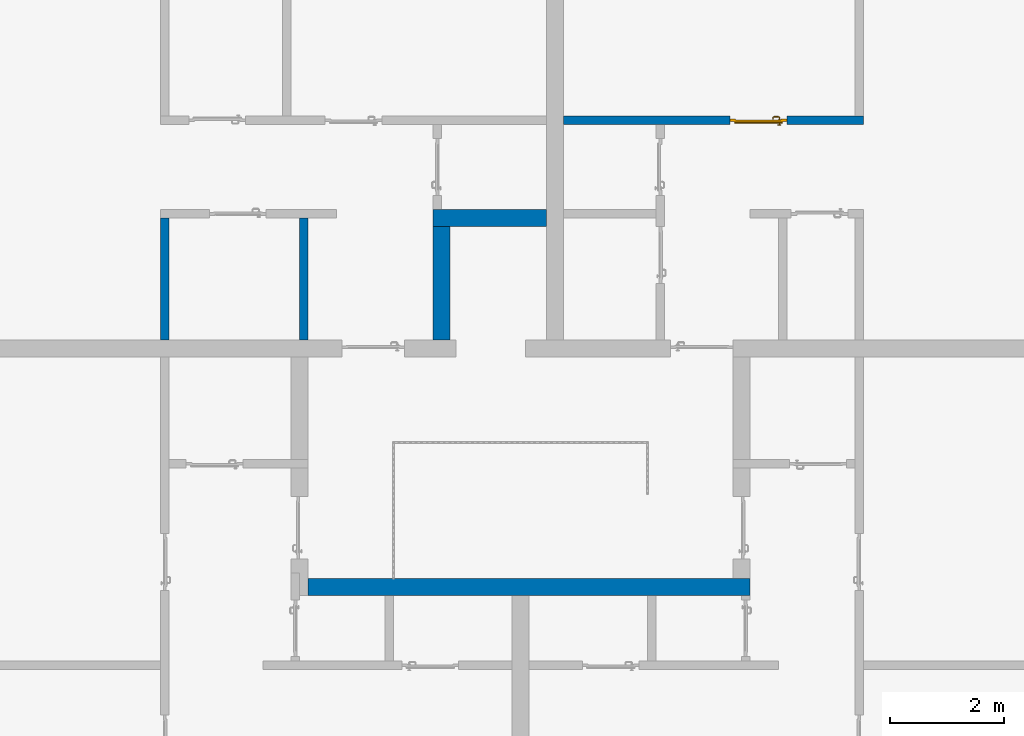
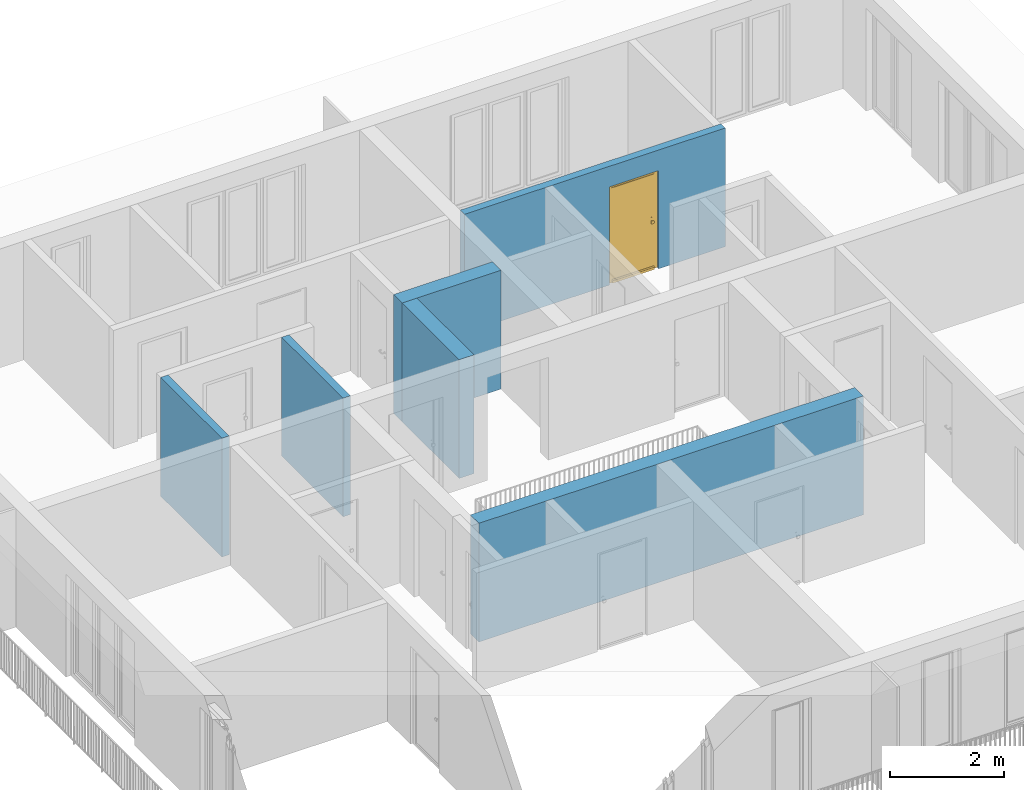
# One storey, part 30 of 54: 6 walls, 1 door, 1 opening.
"""IFC4 building model written with IfcOpenShell, lengths in metres."""

import ifcopenshell
import ifcopenshell.guid

model = None  # the IFC model being written
_history = None  # IfcOwnerHistory: only IFC2X3 demands one
_inside = {}  # id of a spatial element -> (the spatial element, [elements in it])
_under = {}  # id of a project, library or spatial element -> (it, [spatial elements below it])
_declared = {}  # id of a project -> (the project, [libraries it declares])
_typed = {}  # id of a type object -> (the type object, [elements of that type])
_made_of = {}  # id of a material, layer set ... -> (it, [elements and type objects made of it])


def new_model(schema):
    """Start an empty IFC model of exactly this schema.

    Asked for "IFC4X3", IfcOpenShell would pick the latest addendum, in which some entities
    have other attributes; the version numbers below select the first issue.
    IFC2X3 requires an IfcOwnerHistory on every rooted entity: one is made here for all.
    """
    global model, _history
    if schema == "IFC4X3":
        model = ifcopenshell.file(schema_version=(4, 3, 0, 0))
    else:
        model = ifcopenshell.file(schema=schema)
    _inside.clear()
    _under.clear()
    _declared.clear()
    _typed.clear()
    _made_of.clear()
    _history = None
    if model.schema == "IFC2X3":
        org = make("IfcOrganization", Name="unknown")
        user = make(
            "IfcPersonAndOrganization",
            ThePerson=make("IfcPerson", FamilyName="unknown"),
            TheOrganization=org,
        )
        app = make(
            "IfcApplication",
            ApplicationDeveloper=org,
            Version="unknown",
            ApplicationFullName="unknown",
            ApplicationIdentifier="unknown",
        )
        _history = make(
            "IfcOwnerHistory",
            OwningUser=user,
            OwningApplication=app,
            ChangeAction="ADDED",
            CreationDate=0,
        )
    return model


def make(cls, **values):
    """One entity of the class cls with the attributes given. An attribute that is None is left unset."""
    return model.create_entity(
        cls, **{name: value for name, value in values.items() if value is not None}
    )


def entity(cls, *values):
    """Any entity or typed value of the class cls, its attributes in the order of the schema. None: left unset."""
    e = model.create_entity(cls)
    for i, value in enumerate(values):
        if value is not None:
            e[i] = value
    return e


def rooted(cls, **values):
    """An entity with a GlobalId (a new one), such as an element, a storey or a relation."""
    return make(cls, GlobalId=ifcopenshell.guid.new(), OwnerHistory=_history, **values)


def si_unit(unit_type, name, prefix=None):
    """IfcSIUnit, for example si_unit("LENGTHUNIT", "METRE", prefix="MILLI")."""
    return make("IfcSIUnit", UnitType=unit_type, Prefix=prefix, Name=name)


def converted_unit(unit_type, name, factor, base, dimensions=None, offset=None):
    """IfcConversionBasedUnit, such as the inch: factor (a typed value) times the base unit."""
    return make(
        "IfcConversionBasedUnit"
        if offset is None
        else "IfcConversionBasedUnitWithOffset",
        ConversionOffset=offset,
        Dimensions=None
        if dimensions is None
        else entity("IfcDimensionalExponents", *dimensions),
        UnitType=unit_type,
        Name=name,
        ConversionFactor=make(
            "IfcMeasureWithUnit", ValueComponent=factor, UnitComponent=base
        ),
    )


def derived_unit(unit_type, elements):
    """IfcDerivedUnit: a product of units, each with its exponent."""
    return make(
        "IfcDerivedUnit",
        Elements=[
            make("IfcDerivedUnitElement", Unit=unit, Exponent=power)
            for unit, power in elements
        ],
        UnitType=unit_type,
    )


def assignment(units):
    """IfcUnitAssignment: the units of a project."""
    return None if units is None else make("IfcUnitAssignment", Units=units)


def point(xyz):
    """IfcCartesianPoint."""
    return None if xyz is None else make("IfcCartesianPoint", Coordinates=xyz)


def direction(xyz):
    """IfcDirection."""
    return None if xyz is None else make("IfcDirection", DirectionRatios=xyz)


def frame(location, z_axis=None, x_axis=None):
    """IfcAxis2Placement3D, a coordinate frame: its origin and axes. An axis left out is left unset."""
    return make(
        "IfcAxis2Placement3D",
        Location=point(location),
        Axis=direction(z_axis),
        RefDirection=direction(x_axis),
    )


def origin_with_axes():
    """The frame at (0, 0, 0) with the z axis (0, 0, 1) and the x axis (1, 0, 0) written out."""
    return frame((0.0, 0.0, 0.0), z_axis=(0.0, 0.0, 1.0), x_axis=(1.0, 0.0, 0.0))


def place(relative_to, where):
    """IfcLocalPlacement: puts the frame where relative to a parent placement (None: the world)."""
    return make(
        "IfcLocalPlacement", PlacementRelTo=relative_to, RelativePlacement=where
    )


def context(
    kind, dimensions, precision=None, world=None, true_north=None, identifier=None
):
    """IfcGeometricRepresentationContext, for example the 3D "Model" context."""
    return make(
        "IfcGeometricRepresentationContext",
        ContextIdentifier=identifier,
        ContextType=kind,
        CoordinateSpaceDimension=dimensions,
        Precision=precision,
        WorldCoordinateSystem=world,
        TrueNorth=true_north,
    )


def subcontext(parent, identifier, kind, view, scale=None):
    """IfcGeometricRepresentationSubContext, for example "Body" below "Model"."""
    return make(
        "IfcGeometricRepresentationSubContext",
        ContextIdentifier=identifier,
        ContextType=kind,
        ParentContext=parent,
        TargetScale=scale,
        TargetView=view,
    )


def project(units=None, contexts=None):
    """IfcProject with its units and contexts."""
    return rooted(
        "IfcProject",
        Name="project",
        RepresentationContexts=contexts,
        UnitsInContext=assignment(units),
    )


def spatial(cls, under=None, at=None, **own):
    """A site, building, storey or space (cls), placed at a placement, below another one or the project."""
    s = rooted(cls, ObjectPlacement=at, **own)
    if under is not None:
        _under.setdefault(under.id(), (under, []))[1].append(s)
    return s


def point_list(points):
    """IfcCartesianPointList2D or 3D."""
    cls = (
        "IfcCartesianPointList2D" if len(points[0]) == 2 else "IfcCartesianPointList3D"
    )
    return make(cls, CoordList=points)


def polygons(points, faces, closed=None, point_numbers=None):
    """IfcPolygonalFaceSet: a face is its outer loop, then its inner loops; points numbered from 1."""
    made = []
    for loops in faces:
        if len(loops) == 1:
            made.append(make("IfcIndexedPolygonalFace", CoordIndex=loops[0]))
        else:
            made.append(
                make(
                    "IfcIndexedPolygonalFaceWithVoids",
                    CoordIndex=loops[0],
                    InnerCoordIndices=loops[1:],
                )
            )
    return make(
        "IfcPolygonalFaceSet",
        Coordinates=point_list(points),
        Closed=closed,
        Faces=made,
        PnIndex=point_numbers,
    )


def shape(context_of_items, identifier, shape_type, items):
    """IfcShapeRepresentation: the items that make up one representation, for example the "Body"."""
    return make(
        "IfcShapeRepresentation",
        ContextOfItems=context_of_items,
        RepresentationIdentifier=identifier,
        RepresentationType=shape_type,
        Items=items,
    )


def source(mapping_origin, context_of_items, identifier, shape_type, items):
    """IfcRepresentationMap: a shape defined once, which mapped items show again and again."""
    return make(
        "IfcRepresentationMap",
        MappingOrigin=mapping_origin,
        MappedRepresentation=shape(context_of_items, identifier, shape_type, items),
    )


def transform(
    local_origin,
    x_axis=None,
    y_axis=None,
    z_axis=None,
    scale=None,
    scale2=None,
    scale3=None,
    uniform=True,
):
    """IfcCartesianTransformationOperator3D, or its non-uniform kind. x_axis, y_axis, z_axis: its Axis1, 2, 3."""
    if uniform:
        return make(
            "IfcCartesianTransformationOperator3D",
            Axis1=direction(x_axis),
            Axis2=direction(y_axis),
            LocalOrigin=point(local_origin),
            Scale=scale,
            Axis3=direction(z_axis),
        )
    return make(
        "IfcCartesianTransformationOperator3DnonUniform",
        Axis1=direction(x_axis),
        Axis2=direction(y_axis),
        LocalOrigin=point(local_origin),
        Scale=scale,
        Axis3=direction(z_axis),
        Scale2=scale2,
        Scale3=scale3,
    )


def mapped(mapping_source, mapping_target):
    """IfcMappedItem: shows the shape of a source again, moved by a transform."""
    return make(
        "IfcMappedItem", MappingSource=mapping_source, MappingTarget=mapping_target
    )


def material(Name=None, Category=None):
    """IfcMaterial."""
    return make("IfcMaterial", Name=Name, Category=Category)


def made_of(thing, what):
    """Note that an element or type object is made of a material, layer set ...; save() writes the relation."""
    if what is not None:
        _made_of.setdefault(what.id(), (what, []))[1].append(thing)
    return thing


def type_object(cls, material=None, **own):
    """A type object (cls), such as IfcWallType, which elements share."""
    return made_of(rooted(cls, **own), material)


def element(
    cls,
    number,
    at=None,
    inside=None,
    cuts=None,
    type_object=None,
    material=None,
    context=None,
    identifier="Body",
    shape_type=None,
    held_by="IfcProductDefinitionShape",
    body=None,
    shapes=None,
    **own,
):
    """One element of the class cls, such as IfcWall. Its Tag is "e" and its number.

    at: its placement. inside: the storey or other place that contains it. cuts: it is an
    opening in that element (IfcRelVoidsElement). A single representation is given by context,
    identifier, shape_type and body (its items); several are given by shapes. held_by: the class
    of the entity that holds the representations. save() writes the other relations.
    """
    e = rooted(cls, Tag="e%d" % number, ObjectPlacement=at, **own)
    if body is not None:
        shapes = [shape(context, identifier, shape_type, body)]
    if shapes is not None:
        e.Representation = make(held_by, Representations=shapes)
    if inside is not None:
        _inside.setdefault(inside.id(), (inside, []))[1].append(e)
    if cuts is not None:
        rooted(
            "IfcRelVoidsElement", RelatingBuildingElement=cuts, RelatedOpeningElement=e
        )
    if type_object is not None:
        _typed.setdefault(type_object.id(), (type_object, []))[1].append(e)
    return made_of(e, material)


def fill(opening, filler):
    """IfcRelFillsElement: the door or window that sits in an opening."""
    return rooted(
        "IfcRelFillsElement",
        RelatingOpeningElement=opening,
        RelatedBuildingElement=filler,
    )


def aggregate(whole, parts):
    """IfcRelAggregates: a whole, such as a stair, and the parts it consists of."""
    return rooted("IfcRelAggregates", RelatingObject=whole, RelatedObjects=parts)


def save(model, path):
    """Write the relations noted so far, then the file.

    IfcRelAggregates (storeys below a building ...), IfcRelContainedInSpatialStructure (elements
    in a storey), IfcRelDefinesByType, IfcRelAssociatesMaterial and IfcRelDeclares: one each for
    every whole, place, type object, material and project.
    """
    for whole, parts in _under.values():
        aggregate(whole, parts)
    for where, things in _inside.values():
        rooted(
            "IfcRelContainedInSpatialStructure",
            RelatedElements=things,
            RelatingStructure=where,
        )
    for kind, things in _typed.values():
        rooted("IfcRelDefinesByType", RelatedObjects=things, RelatingType=kind)
    for what, things in _made_of.values():
        rooted("IfcRelAssociatesMaterial", RelatedObjects=things, RelatingMaterial=what)
    for by, libraries in _declared.values():
        rooted("IfcRelDeclares", RelatingContext=by, RelatedDefinitions=libraries)
    model.write(path)


model = new_model("IFC4")

# Units and contexts
model_context = context("Model", 3, precision=1e-05, world=origin_with_axes(), true_north=direction((0.0, 1.0)))
body_context = subcontext(model_context, "Body", "Model", "MODEL_VIEW")
ifc_project = project(units=[si_unit("LENGTHUNIT", "METRE"), si_unit("AREAUNIT", "SQUARE_METRE"), si_unit("VOLUMEUNIT", "CUBIC_METRE"), converted_unit("PLANEANGLEUNIT", "DEGREE", entity("IfcPlaneAngleMeasure", 0.0174532925199), si_unit("PLANEANGLEUNIT", "RADIAN"), dimensions=[0, 0, 0, 0, 0, 0, 0]), converted_unit("TIMEUNIT", "Year", entity("IfcTimeMeasure", 31556926.0), si_unit("TIMEUNIT", "SECOND"), dimensions=[0, 0, 1, 0, 0, 0, 0]), si_unit("MASSUNIT", "GRAM", prefix="KILO"), si_unit("THERMODYNAMICTEMPERATUREUNIT", "DEGREE_CELSIUS"), si_unit("LUMINOUSINTENSITYUNIT", "LUMEN"), si_unit("ENERGYUNIT", "JOULE", prefix="MEGA"), derived_unit("THERMALCONDUCTANCEUNIT", [(si_unit("POWERUNIT", "WATT"), 1), (si_unit("LENGTHUNIT", "METRE"), -1), (si_unit("THERMODYNAMICTEMPERATUREUNIT", "KELVIN"), -1)]), derived_unit("SPECIFICHEATCAPACITYUNIT", [(si_unit("ENERGYUNIT", "JOULE"), 1), (si_unit("MASSUNIT", "GRAM", prefix="KILO"), -1), (si_unit("THERMODYNAMICTEMPERATUREUNIT", "KELVIN"), -1)]), derived_unit("MASSDENSITYUNIT", [(si_unit("MASSUNIT", "GRAM", prefix="KILO"), 1), (si_unit("VOLUMEUNIT", "CUBIC_METRE"), -1)])], contexts=[model_context])

# Site, building, storey
site_placement = place(None, origin_with_axes())
site = spatial("IfcSite", under=ifc_project, at=site_placement, CompositionType="ELEMENT")
building_placement = place(site_placement, origin_with_axes())
building = spatial("IfcBuilding", under=site, at=building_placement, CompositionType="ELEMENT")
storey_placement = place(building_placement, frame((0.0, 0.0, 9.18), z_axis=(0.0, 0.0, 1.0), x_axis=(1.0, 0.0, 0.0)))
storey = spatial("IfcBuildingStorey", under=building, at=storey_placement, Name="3. Geschoss", CompositionType="ELEMENT", Elevation=9.18)

# Walls
ifc_material = material()
wall_type_1 = type_object("IfcWallType", Name="300", PredefinedType="NOTDEFINED")
wall_1_placement = place(storey_placement, frame((2.8378006196, -2.52881223104, 0.0), z_axis=(0.0, 0.0, 1.0), x_axis=(-1.0, 0.0, 0.0)))
element("IfcWall", 1, at=wall_1_placement, inside=storey, type_object=wall_type_1, material=ifc_material, Name="Wand-001", PredefinedType="NOTDEFINED", context=body_context, shape_type="Tessellation", body=[
    polygons([(7.78, 0.0, 0.0), (7.78, 0.0, 2.54), (0.0, 0.0, 2.54), (0.0, 0.0, 0.0), (7.78, 0.3, 0.0), (7.78, 0.3, 2.54), (0.0, 0.3, 2.54), (0.0, 0.3, 0.0)], [[[1, 2, 3, 4]], [[5, 6, 2, 1]], [[6, 7, 3, 2]], [[4, 3, 7, 8]], [[4, 8, 5, 1]], [[8, 7, 6, 5]]], closed=True),
])
wall_2_placement = place(storey_placement, frame((-2.7421993804, 3.67118776896, 0.0), z_axis=(0.0, 0.0, 1.0), x_axis=(1.0, 0.0, 0.0)))
element("IfcWall", 2, at=wall_2_placement, inside=storey, type_object=wall_type_1, material=ifc_material, Name="Wand-001", PredefinedType="NOTDEFINED", context=body_context, shape_type="Tessellation", body=[
    polygons([(0.0, 0.3, 0.0), (0.0, 0.3, 2.54), (2.0, 0.3, 2.54), (2.0, 0.3, 0.0), (0.0, 0.0, 0.0), (0.0, 0.0, 2.54), (2.0, 0.0, 2.54), (2.0, 0.0, 0.0)], [[[1, 2, 3, 4]], [[5, 6, 2, 1]], [[6, 7, 3, 2]], [[4, 3, 7, 8]], [[5, 1, 4, 8]], [[8, 7, 6, 5]]], closed=True),
])
wall_3_placement = place(storey_placement, frame((-2.7421993804, 1.37118776896, 0.0), z_axis=(0.0, 0.0, 1.0), x_axis=(0.0, 1.0, 0.0)))
element("IfcWall", 3, at=wall_3_placement, inside=storey, type_object=wall_type_1, material=ifc_material, Name="Wand-001", PredefinedType="NOTDEFINED", context=body_context, shape_type="Tessellation", body=[
    polygons([(2.3, 0.0, 0.0), (2.3, 0.0, 2.54), (2.3, -0.3, 2.54), (2.3, -0.3, 0.0), (0.3, 0.0, 0.0), (0.3, 0.0, 2.54), (0.3, -0.3, 2.54), (0.3, -0.3, 0.0)], [[[1, 2, 3, 4]], [[5, 6, 2, 1]], [[6, 7, 3, 2]], [[4, 3, 7, 8]], [[5, 1, 4, 8]], [[8, 7, 6, 5]]], closed=True),
])
wall_type_2 = type_object("IfcWallType", Name="150", PredefinedType="NOTDEFINED")
wall_4_placement = place(storey_placement, frame((-4.9421993804, 1.37118776896, 0.0), z_axis=(0.0, 0.0, 1.0), x_axis=(0.0, 1.0, 0.0)))
element("IfcWall", 4, at=wall_4_placement, inside=storey, type_object=wall_type_2, material=ifc_material, Name="Wand-002", PredefinedType="NOTDEFINED", context=body_context, shape_type="Tessellation", body=[
    polygons([(2.45, 0.15, 0.0), (2.45, 0.15, 2.54), (2.45, 0.0, 2.54), (2.45, 0.0, 0.0), (0.3, 0.15, 0.0), (0.3, 0.15, 2.54), (0.3, 0.0, 2.54), (0.3, 0.0, 0.0)], [[[1, 2, 3, 4]], [[5, 6, 2, 1]], [[6, 7, 3, 2]], [[4, 3, 7, 8]], [[5, 1, 4, 8]], [[8, 7, 6, 5]]], closed=True),
])
wall_5_placement = place(storey_placement, frame((-7.5421993804, 3.97118776896, 0.0), z_axis=(0.0, 0.0, 1.0), x_axis=(0.0, -1.0, 0.0)))
element("IfcWall", 5, at=wall_5_placement, inside=storey, type_object=wall_type_2, material=ifc_material, Name="Wand-003", PredefinedType="NOTDEFINED", context=body_context, shape_type="Tessellation", body=[
    polygons([(0.15, 0.0, 0.0), (0.15, 0.0, 2.54), (0.15, 0.15, 2.54), (0.15, 0.15, 0.0), (2.3, 0.0, 0.0), (2.3, 0.0, 2.54), (2.3, 0.15, 2.54), (2.3, 0.15, 0.0)], [[[1, 2, 3, 4]], [[5, 6, 2, 1]], [[6, 7, 3, 2]], [[4, 3, 7, 8]], [[1, 4, 8, 5]], [[8, 7, 6, 5]]], closed=True),
])

# Wall, opening, door
wall_6_placement = place(storey_placement, frame((-0.742199380397, 5.47118776896, 0.0), z_axis=(0.0, 0.0, 1.0), x_axis=(1.0, 0.0, 0.0)))
wall_6 = element("IfcWall", 6, at=wall_6_placement, inside=storey, type_object=wall_type_2, material=ifc_material, Name="Wand-002", PredefinedType="NOTDEFINED", context=body_context, shape_type="Tessellation", body=[
    polygons([(3.23, 0.15, 2.1), (3.23, 0.15, 0.0), (0.3, 0.15, 0.0), (0.3, 0.15, 2.54), (5.58, 0.15, 2.54), (5.58, 0.15, 0.0), (4.23, 0.15, 0.0), (4.23, 0.15, 2.1), (3.23, 0.05, 2.1), (3.23, 0.05, 0.0), (3.23, 0.0, 0.0), (0.3, 0.0, 0.0), (0.3, 0.0, 2.54), (5.58, 0.0, 2.54), (5.58, 0.0, 0.0), (4.23, 0.05, 0.0), (4.23, 0.0, 0.0), (4.23, 0.05, 2.1), (3.23, 0.0, 2.1), (4.23, 0.0, 2.1)], [[[1, 2, 3, 4, 5, 6, 7, 8]], [[2, 1, 9, 10]], [[2, 10, 11, 12, 3]], [[4, 3, 12, 13]], [[5, 4, 13, 14]], [[14, 15, 6, 5]], [[16, 7, 6, 15, 17]], [[8, 7, 16, 18]], [[1, 8, 18, 9]], [[10, 9, 19, 11]], [[12, 11, 19, 20, 17, 15, 14, 13]], [[18, 16, 17, 20]], [[9, 18, 20, 19]]], closed=True),
])
opening_placement = place(wall_6_placement, frame((3.73, 0.0, 0.0), z_axis=(0.0, 0.0, 1.0), x_axis=(1.0, 0.0, 0.0)))
opening = element("IfcOpeningElement", 7, at=opening_placement, cuts=wall_6, context=body_context, identifier="Reference", shape_type="Tessellation", body=[
    polygons([(0.5, 0.05, 0.0), (0.5, 0.05, 2.1), (0.5, -0.001, 2.1), (0.5, -0.001, 0.0), (0.5, 0.151, 0.0), (0.5, 0.151, 2.1), (-0.5, 0.05, 2.1), (-0.5, -0.001, 2.1), (-0.5, 0.151, 2.1), (-0.5, -0.001, 0.0), (-0.5, 0.05, 0.0), (-0.5, 0.151, 0.0)], [[[1, 2, 3, 4]], [[2, 1, 5, 6]], [[7, 8, 3, 2, 6, 9]], [[8, 10, 4, 3]], [[1, 4, 10, 11, 12, 5]], [[6, 5, 12, 9]], [[7, 11, 10, 8]], [[11, 7, 9, 12]]], closed=True),
])
door_type = type_object("IfcDoorType", Name="Eingang 01 1-Fl 26", OperationType="SINGLE_SWING_RIGHT", PredefinedType="DOOR")
shared_shape = source(origin_with_axes(), body_context, "Body", "Tessellation", [
    polygons([(0.5, -0.05, 0.0), (0.5, -0.03, 0.0), (0.5, -0.03, 2.1), (0.5, -0.05, 2.1), (0.4, -0.05, 0.0), (0.4, -0.03, 0.0), (0.4, -0.03, 2.0), (0.1301, -0.03, 2.0), (0.0001, -0.03, 2.0), (-0.4, -0.03, 2.0), (-0.4, -0.03, 0.0), (-0.5, -0.03, 0.0), (-0.5, -0.03, 2.1), (-0.5, -0.05, 2.1), (-0.5, -0.05, 0.0), (-0.4, -0.05, 0.0), (-0.4, -0.05, 2.0), (0.0001, -0.05, 2.0), (0.1301, -0.05, 2.0), (0.4, -0.05, 2.0)], [[[1, 2, 3, 4]], [[5, 6, 2, 1]], [[2, 6, 7, 8, 9, 10, 11, 12, 13, 3]], [[4, 3, 13, 14]], [[1, 4, 14, 15, 16, 17, 18, 19, 20, 5]], [[20, 7, 6, 5]], [[19, 8, 7, 20]], [[18, 9, 8, 19]], [[17, 10, 9, 18]], [[16, 11, 10, 17]], [[15, 12, 11, 16]], [[14, 13, 12, 15]]], closed=True),
    polygons([(0.5, -0.03, 0.0), (0.5, 0.0, 0.0), (0.5, 0.0, 2.1), (0.5, -0.03, 2.1), (0.43, -0.03, 0.0), (0.43, 0.0, 0.0), (0.43, 0.0, 2.03), (0.1001, 0.0, 2.03), (0.0301, 0.0, 2.03), (-0.43, 0.0, 2.03), (-0.43, 0.0, 0.0), (-0.5, 0.0, 0.0), (-0.5, 0.0, 2.1), (-0.5, -0.03, 2.1), (-0.5, -0.03, 0.0), (-0.43, -0.03, 0.0), (-0.43, -0.03, 2.03), (0.0301, -0.03, 2.03), (0.1001, -0.03, 2.03), (0.43, -0.03, 2.03)], [[[1, 2, 3, 4]], [[5, 6, 2, 1]], [[2, 6, 7, 8, 9, 10, 11, 12, 13, 3]], [[4, 3, 13, 14]], [[1, 4, 14, 15, 16, 17, 18, 19, 20, 5]], [[20, 7, 6, 5]], [[19, 8, 7, 20]], [[18, 9, 8, 19]], [[17, 10, 9, 18]], [[16, 11, 10, 17]], [[15, 12, 11, 16]], [[14, 13, 12, 15]]], closed=True),
    polygons([(0.43, 0.01, 0.0), (-0.43, 0.01, 0.0), (-0.43, 0.01, 2.03), (0.43, 0.01, 2.03), (0.43, -0.03, 0.0), (-0.43, -0.03, 0.0), (-0.43, -0.03, 2.03), (0.43, -0.03, 2.03)], [[[1, 2, 3, 4]], [[2, 1, 5, 6]], [[3, 2, 6, 7]], [[4, 3, 7, 8]], [[1, 4, 8, 5]], [[6, 5, 8, 7]]], closed=True),
    polygons([(0.425, 0.03, 0.0), (-0.425, 0.03, 0.0), (-0.425, 0.03, 0.05), (0.425, 0.03, 0.05), (0.425, 0.01, 0.0), (-0.425, 0.01, 0.0), (-0.425, 0.01, 0.07), (-0.425, 0.015, 0.07), (0.425, 0.015, 0.07), (0.425, 0.01, 0.07)], [[[1, 2, 3, 4]], [[5, 6, 2, 1]], [[2, 6, 7, 8, 3]], [[4, 3, 8, 9]], [[1, 4, 9, 10, 5]], [[10, 7, 6, 5]], [[9, 8, 7, 10]]], closed=True),
    polygons([(-0.3835, -0.04, 1.0733826859), (-0.37, -0.04, 1.077), (-0.37, -0.0399, 1.077), (-0.3835, -0.0399, 1.0733826859), (-0.393382685902, -0.04, 1.0635), (-0.397, -0.04, 1.05), (-0.393382685902, -0.04, 1.0365), (-0.3835, -0.04, 1.0266173141), (-0.37, -0.04, 1.023), (-0.3565, -0.04, 1.0266173141), (-0.346617314098, -0.04, 1.0365), (-0.343, -0.04, 1.05), (-0.346617314098, -0.04, 1.0635), (-0.3565, -0.04, 1.0733826859), (-0.3565, -0.0399, 1.0733826859), (-0.37, -0.0301, 1.077), (-0.3835, -0.0301, 1.0733826859), (-0.393382685902, -0.0399, 1.0635), (-0.397, -0.0399, 1.05), (-0.393382685902, -0.0399, 1.0365), (-0.3835, -0.0399, 1.0266173141), (-0.37, -0.0399, 1.023), (-0.3565, -0.0399, 1.0266173141), (-0.346617314098, -0.0399, 1.0365), (-0.343, -0.0399, 1.05), (-0.346617314098, -0.0399, 1.0635), (-0.3565, -0.0301, 1.0733826859), (-0.37, -0.03, 1.077), (-0.3835, -0.03, 1.0733826859), (-0.393382685902, -0.0301, 1.0635), (-0.397, -0.0301, 1.05), (-0.393382685902, -0.0301, 1.0365), (-0.3835, -0.0301, 1.0266173141), (-0.37, -0.0301, 1.023), (-0.3565, -0.0301, 1.0266173141), (-0.346617314098, -0.0301, 1.0365), (-0.343, -0.0301, 1.05), (-0.346617314098, -0.0301, 1.0635), (-0.3565, -0.03, 1.0733826859), (-0.346617314098, -0.03, 1.0635), (-0.343, -0.03, 1.05), (-0.346617314098, -0.03, 1.0365), (-0.3565, -0.03, 1.0266173141), (-0.37, -0.03, 1.023), (-0.3835, -0.03, 1.0266173141), (-0.393382685902, -0.03, 1.0365), (-0.397, -0.03, 1.05), (-0.393382685902, -0.03, 1.0635)], [[[1, 2, 3, 4]], [[2, 1, 5, 6, 7, 8, 9, 10, 11, 12, 13, 14]], [[2, 14, 15, 3]], [[4, 3, 16, 17]], [[5, 1, 4, 18]], [[6, 5, 18, 19]], [[7, 6, 19, 20]], [[8, 7, 20, 21]], [[9, 8, 21, 22]], [[10, 9, 22, 23]], [[11, 10, 23, 24]], [[12, 11, 24, 25]], [[13, 12, 25, 26]], [[14, 13, 26, 15]], [[3, 15, 27, 16]], [[17, 16, 28, 29]], [[18, 4, 17, 30]], [[19, 18, 30, 31]], [[20, 19, 31, 32]], [[21, 20, 32, 33]], [[22, 21, 33, 34]], [[23, 22, 34, 35]], [[24, 23, 35, 36]], [[25, 24, 36, 37]], [[26, 25, 37, 38]], [[15, 26, 38, 27]], [[16, 27, 39, 28]], [[28, 39, 40, 41, 42, 43, 44, 45, 46, 47, 48, 29]], [[30, 17, 29, 48]], [[31, 30, 48, 47]], [[32, 31, 47, 46]], [[33, 32, 46, 45]], [[34, 33, 45, 44]], [[35, 34, 44, 43]], [[36, 35, 43, 42]], [[37, 36, 42, 41]], [[38, 37, 41, 40]], [[27, 38, 40, 39]]], closed=True),
    polygons([(-0.362532169224, -0.04, 0.959692280177), (-0.365, -0.04, 0.9544), (-0.365, -0.04, 0.952886751346), (-0.346703916638, -0.04, 0.96345), (-0.35655, -0.04, 0.973296083362), (-0.363279754556, -0.04, 0.961639806549), (-0.362532169224, -0.039, 0.959692280177), (-0.365, -0.039, 0.9544), (-0.365, -0.039, 0.952886751346), (-0.365, -0.039, 0.95), (-0.365, -0.039, 0.947113248654), (-0.365, -0.039, 0.941339745962), (-0.365, -0.039, 0.9375), (-0.365, -0.04, 0.9375), (-0.365, -0.04, 0.941339745962), (-0.365, -0.04, 0.947113248654), (-0.365, -0.04, 0.95), (-0.3431, -0.04, 0.95), (-0.346617314098, -0.04, 0.9635), (-0.3565, -0.04, 0.973382685902), (-0.364624817685, -0.04, 0.965143815798), (-0.37, -0.04, 0.9769), (-0.37, -0.04, 0.967425445323), (-0.364624817685, -0.039, 0.965143815798), (-0.363279754556, -0.039, 0.961639806549), (-0.35705, -0.039, 0.972430057958), (-0.347569942042, -0.039, 0.96295), (-0.3441, -0.039, 0.95), (-0.347569942042, -0.039, 0.93705), (-0.35705, -0.039, 0.927569942042), (-0.37, -0.039, 0.9241), (-0.37, -0.039, 0.9325), (-0.366464466094, -0.039, 0.933964466094), (-0.366464466094, -0.04, 0.933964466094), (-0.35655, -0.04, 0.926703916638), (-0.37, -0.04, 0.9325), (-0.37, -0.04, 0.9231), (-0.346703916638, -0.04, 0.93655), (-0.343, -0.04, 0.95), (-0.346617314098, -0.0399, 0.9635), (-0.3565, -0.0399, 0.973382685902), (-0.37, -0.04, 0.977), (-0.375375182315, -0.04, 0.965143815798), (-0.38345, -0.04, 0.973296083362), (-0.376720245444, -0.04, 0.961639806549), (-0.37, -0.039, 0.967425445323), (-0.37, -0.039, 0.9759), (-0.357, -0.039, 0.972516660498), (-0.347483339502, -0.039, 0.963), (-0.344, -0.039, 0.95), (-0.347483339502, -0.039, 0.937), (-0.357, -0.039, 0.927483339502), (-0.38295, -0.039, 0.927569942042), (-0.375, -0.039, 0.941339745962), (-0.375, -0.039, 0.9375), (-0.373535533906, -0.039, 0.933964466094), (-0.37, -0.039, 0.924), (-0.373535533906, -0.04, 0.933964466094), (-0.375, -0.04, 0.9375), (-0.375, -0.04, 0.941339745962), (-0.38345, -0.04, 0.926703916638), (-0.37, -0.04, 0.923), (-0.3565, -0.04, 0.926617314098), (-0.346617314098, -0.04, 0.9365), (-0.343, -0.0399, 0.95), (-0.346617314098, -0.0301, 0.9635), (-0.3565, -0.0301, 0.973382685902), (-0.37, -0.0399, 0.977), (-0.3835, -0.04, 0.973382685902), (-0.375375182315, -0.039, 0.965143815798), (-0.377467830776, -0.04, 0.959692280177), (-0.393296083362, -0.04, 0.96345), (-0.375, -0.04, 0.952886751346), (-0.375, -0.04, 0.9544), (-0.377467830776, -0.039, 0.959692280177), (-0.376720245444, -0.039, 0.961639806549), (-0.38295, -0.039, 0.972430057958), (-0.37, -0.039, 0.976), (-0.357, -0.0389, 0.972516660498), (-0.347483339502, -0.0389, 0.963), (-0.344, -0.0389, 0.95), (-0.347483339502, -0.0389, 0.937), (-0.357, -0.0389, 0.927483339502), (-0.392430057958, -0.039, 0.93705), (-0.375, -0.039, 0.947113248654), (-0.375, -0.039, 0.9544), (-0.375, -0.04, 0.95), (-0.375, -0.04, 0.947113248654), (-0.375, -0.039, 0.95), (-0.375, -0.039, 0.952886751346), (-0.383, -0.039, 0.927483339502), (-0.37, -0.0389, 0.924), (-0.393296083362, -0.04, 0.93655), (-0.3835, -0.04, 0.926617314098), (-0.37, -0.0399, 0.923), (-0.3565, -0.0399, 0.926617314098), (-0.346617314098, -0.0399, 0.9365), (-0.343, -0.0301, 0.95), (-0.346617314098, -0.03, 0.9635), (-0.3565, -0.03, 0.973382685902), (-0.37, -0.0301, 0.977), (-0.3835, -0.0399, 0.973382685902), (-0.393382685902, -0.04, 0.9635), (-0.3969, -0.04, 0.95), (-0.392430057958, -0.039, 0.96295), (-0.383, -0.039, 0.972516660498), (-0.37, -0.0389, 0.976), (-0.357, -0.0301, 0.972516660498), (-0.347483339502, -0.0301, 0.963), (-0.344, -0.0301, 0.95), (-0.347483339502, -0.0301, 0.937), (-0.357, -0.0301, 0.927483339502), (-0.392516660498, -0.039, 0.937), (-0.3959, -0.039, 0.95), (-0.383, -0.0389, 0.927483339502), (-0.37, -0.0301, 0.924), (-0.393382685902, -0.04, 0.9365), (-0.3835, -0.0399, 0.926617314098), (-0.37, -0.0301, 0.923), (-0.3565, -0.0301, 0.926617314098), (-0.346617314098, -0.0301, 0.9365), (-0.343, -0.03, 0.95), (-0.346703916638, -0.03, 0.96345), (-0.35655, -0.03, 0.973296083362), (-0.37, -0.03, 0.977), (-0.3835, -0.0301, 0.973382685902), (-0.393382685902, -0.0399, 0.9635), (-0.397, -0.04, 0.95), (-0.392516660498, -0.039, 0.963), (-0.383, -0.0389, 0.972516660498), (-0.37, -0.0301, 0.976), (-0.357, -0.03, 0.972516660498), (-0.347483339502, -0.03, 0.963), (-0.344, -0.03, 0.95), (-0.347483339502, -0.03, 0.937), (-0.357, -0.03, 0.927483339502), (-0.392516660498, -0.0389, 0.937), (-0.396, -0.039, 0.95), (-0.383, -0.0301, 0.927483339502), (-0.37, -0.03, 0.924), (-0.393382685902, -0.0399, 0.9365), (-0.3835, -0.0301, 0.926617314098), (-0.37, -0.03, 0.923), (-0.3565, -0.03, 0.926617314098), (-0.346617314098, -0.03, 0.9365), (-0.3431, -0.03, 0.95), (-0.347396736961, -0.03, 0.96305), (-0.35695, -0.03, 0.972603263039), (-0.37, -0.03, 0.9769), (-0.3835, -0.03, 0.973382685902), (-0.393382685902, -0.0301, 0.9635), (-0.397, -0.0399, 0.95), (-0.392516660498, -0.0389, 0.963), (-0.383, -0.0301, 0.972516660498), (-0.37, -0.03, 0.976), (-0.3439, -0.03, 0.95), (-0.347396736961, -0.03, 0.93695), (-0.35695, -0.03, 0.927396736961), (-0.392516660498, -0.0301, 0.937), (-0.396, -0.0389, 0.95), (-0.383, -0.03, 0.927483339502), (-0.37, -0.03, 0.9239), (-0.393382685902, -0.0301, 0.9365), (-0.3835, -0.03, 0.926617314098), (-0.37, -0.03, 0.9231), (-0.35655, -0.03, 0.926703916638), (-0.346703916638, -0.03, 0.93655), (-0.37, -0.03, 0.9761), (-0.38345, -0.03, 0.973296083362), (-0.393382685902, -0.03, 0.9635), (-0.397, -0.0301, 0.95), (-0.392516660498, -0.0301, 0.963), (-0.383, -0.03, 0.972516660498), (-0.392516660498, -0.03, 0.937), (-0.396, -0.0301, 0.95), (-0.38305, -0.03, 0.927396736961), (-0.393382685902, -0.03, 0.9365), (-0.38345, -0.03, 0.926703916638), (-0.38305, -0.03, 0.972603263039), (-0.393296083362, -0.03, 0.96345), (-0.397, -0.03, 0.95), (-0.392516660498, -0.03, 0.963), (-0.392603263039, -0.03, 0.93695), (-0.396, -0.03, 0.95), (-0.393296083362, -0.03, 0.93655), (-0.392603263039, -0.03, 0.96305), (-0.3969, -0.03, 0.95), (-0.3961, -0.03, 0.95)], [[[1, 2, 3, 4, 5, 6]], [[2, 1, 7, 8]], [[2, 8, 9, 10, 11, 12, 13, 14, 15, 16, 17, 3]], [[17, 18, 4, 3]], [[19, 20, 5, 4]], [[21, 6, 5, 22, 23]], [[1, 6, 21, 24, 25, 7]], [[7, 25, 26, 27, 9, 8]], [[9, 27, 28, 10]], [[10, 28, 29, 11]], [[11, 29, 30, 12]], [[31, 32, 33, 13, 12, 30]], [[14, 13, 33, 34]], [[35, 15, 14, 34, 36, 37]], [[15, 35, 38, 16]], [[16, 38, 18, 17]], [[39, 19, 4, 18]], [[40, 41, 20, 19]], [[20, 42, 22, 5]], [[43, 23, 22, 44, 45]], [[21, 23, 46, 24]], [[24, 46, 47, 26, 25]], [[27, 26, 48, 49]], [[28, 27, 49, 50]], [[29, 28, 50, 51]], [[30, 29, 51, 52]], [[53, 54, 55, 56, 32, 31]], [[34, 33, 32, 36]], [[31, 30, 52, 57]], [[37, 36, 58, 59, 60, 61]], [[62, 63, 35, 37]], [[63, 64, 38, 35]], [[64, 39, 18, 38]], [[65, 40, 19, 39]], [[66, 67, 41, 40]], [[41, 68, 42, 20]], [[42, 69, 44, 22]], [[23, 43, 70, 46]], [[71, 45, 44, 72, 73, 74]], [[43, 45, 71, 75, 76, 70]], [[70, 76, 77, 47, 46]], [[26, 47, 78, 48]], [[49, 48, 79, 80]], [[50, 49, 80, 81]], [[51, 50, 81, 82]], [[52, 51, 82, 83]], [[54, 53, 84, 85]], [[86, 74, 73, 87, 88, 60, 59, 55, 54, 85, 89, 90]], [[58, 56, 55, 59]], [[36, 32, 56, 58]], [[53, 31, 57, 91]], [[57, 52, 83, 92]], [[88, 93, 61, 60]], [[94, 62, 37, 61]], [[95, 96, 63, 62]], [[96, 97, 64, 63]], [[97, 65, 39, 64]], [[98, 66, 40, 65]], [[99, 100, 67, 66]], [[67, 101, 68, 41]], [[68, 102, 69, 42]], [[69, 103, 72, 44]], [[73, 72, 104, 87]], [[71, 74, 86, 75]], [[75, 86, 90, 105, 77, 76]], [[47, 77, 106, 78]], [[48, 78, 107, 79]], [[80, 79, 108, 109]], [[81, 80, 109, 110]], [[82, 81, 110, 111]], [[83, 82, 111, 112]], [[84, 53, 91, 113]], [[85, 84, 114, 89]], [[87, 104, 93, 88]], [[89, 114, 105, 90]], [[91, 57, 92, 115]], [[92, 83, 112, 116]], [[117, 94, 61, 93]], [[118, 95, 62, 94]], [[119, 120, 96, 95]], [[120, 121, 97, 96]], [[121, 98, 65, 97]], [[122, 99, 66, 98]], [[123, 124, 100, 99]], [[100, 125, 101, 67]], [[101, 126, 102, 68]], [[102, 127, 103, 69]], [[103, 128, 104, 72]], [[77, 105, 129, 106]], [[78, 106, 130, 107]], [[79, 107, 131, 108]], [[109, 108, 132, 133]], [[110, 109, 133, 134]], [[111, 110, 134, 135]], [[112, 111, 135, 136]], [[113, 91, 115, 137]], [[114, 84, 113, 138]], [[128, 117, 93, 104]], [[105, 114, 138, 129]], [[115, 92, 116, 139]], [[116, 112, 136, 140]], [[141, 118, 94, 117]], [[142, 119, 95, 118]], [[143, 144, 120, 119]], [[144, 145, 121, 120]], [[145, 122, 98, 121]], [[146, 123, 99, 122]], [[147, 148, 124, 123]], [[124, 149, 125, 100]], [[125, 150, 126, 101]], [[126, 151, 127, 102]], [[127, 152, 128, 103]], [[106, 129, 153, 130]], [[107, 130, 154, 131]], [[108, 131, 155, 132]], [[133, 132, 148, 147]], [[134, 133, 147, 156]], [[135, 134, 156, 157]], [[136, 135, 157, 158]], [[137, 115, 139, 159]], [[138, 113, 137, 160]], [[152, 141, 117, 128]], [[129, 138, 160, 153]], [[139, 116, 140, 161]], [[140, 136, 158, 162]], [[163, 142, 118, 141]], [[164, 143, 119, 142]], [[165, 166, 144, 143]], [[166, 167, 145, 144]], [[167, 146, 122, 145]], [[156, 147, 123, 146]], [[148, 168, 149, 124]], [[149, 169, 150, 125]], [[150, 170, 151, 126]], [[151, 171, 152, 127]], [[130, 153, 172, 154]], [[131, 154, 173, 155]], [[132, 155, 168, 148]], [[157, 156, 146, 167]], [[158, 157, 167, 166]], [[159, 139, 161, 174]], [[160, 137, 159, 175]], [[171, 163, 141, 152]], [[153, 160, 175, 172]], [[161, 140, 162, 176]], [[162, 158, 166, 165]], [[177, 164, 142, 163]], [[178, 165, 143, 164]], [[168, 179, 169, 149]], [[169, 180, 170, 150]], [[170, 181, 171, 151]], [[154, 172, 182, 173]], [[155, 173, 179, 168]], [[174, 161, 176, 183]], [[175, 159, 174, 184]], [[181, 177, 163, 171]], [[172, 175, 184, 182]], [[176, 162, 165, 178]], [[185, 178, 164, 177]], [[179, 186, 180, 169]], [[180, 187, 181, 170]], [[173, 182, 186, 179]], [[183, 176, 178, 185]], [[184, 174, 183, 188]], [[187, 185, 177, 181]], [[182, 184, 188, 186]], [[186, 188, 187, 180]], [[188, 183, 185, 187]]], closed=True),
    polygons([(-0.38, -0.04, 1.05), (-0.377071067812, -0.04, 1.04292893219), (-0.377071067812, -0.070696439392, 1.04292893219), (-0.38, -0.0709849140336, 1.05), (-0.37, -0.04, 1.04), (-0.37, -0.07, 1.04), (-0.375518993221, -0.0784992452783, 1.04292893219), (-0.378277987014, -0.0796420579258, 1.05), (-0.377071067812, -0.04, 1.05707106781), (-0.377071067812, -0.070696439392, 1.05707106781), (-0.362928932188, -0.04, 1.04292893219), (-0.362928932188, -0.069303560608, 1.04292893219), (-0.368858192988, -0.0757402514855, 1.04), (-0.370704557509, -0.0857045575088, 1.04292893219), (-0.372816199938, -0.0878161999379, 1.05), (-0.375518993221, -0.0784992452783, 1.05707106781), (-0.37, -0.04, 1.06), (-0.37, -0.07, 1.06), (-0.36, -0.04, 1.05), (-0.36, -0.0690150859664, 1.05), (-0.362197392755, -0.0729812576926, 1.04292893219), (-0.365606601718, -0.0806066017178, 1.04), (-0.363499245278, -0.0905189932208, 1.04292893219), (-0.364642057926, -0.0932779870137, 1.05), (-0.370704557509, -0.0857045575088, 1.05707106781), (-0.368858192988, -0.0757402514855, 1.06), (-0.362928932188, -0.04, 1.05707106781), (-0.362928932188, -0.069303560608, 1.05707106781), (-0.359438398962, -0.0718384450452, 1.05), (-0.360508645927, -0.0755086459268, 1.04292893219), (-0.360740251485, -0.0838581929877, 1.04), (-0.355696439392, -0.0920710678119, 1.04292893219), (-0.355984914034, -0.095, 1.05), (-0.363499245278, -0.0905189932208, 1.05707106781), (-0.365606601718, -0.0806066017178, 1.06), (-0.362197392755, -0.0729812576926, 1.05707106781), (-0.358397003498, -0.0733970034977, 1.05), (-0.357981257693, -0.0771973927545, 1.04292893219), (-0.355, -0.085, 1.04), (-0.274303560608, -0.0920710678119, 1.04292893219), (-0.274015085966, -0.095, 1.05), (-0.355696439392, -0.0920710678119, 1.05707106781), (-0.360740251485, -0.0838581929877, 1.06), (-0.360508645927, -0.0755086459268, 1.05707106781), (-0.356838445045, -0.0744383989617, 1.05), (-0.354303560608, -0.0779289321881, 1.04292893219), (-0.275, -0.085, 1.04), (-0.266500754722, -0.0905189932208, 1.04292893219), (-0.265357942074, -0.0932779870137, 1.05), (-0.274303560608, -0.0920710678119, 1.05707106781), (-0.355, -0.085, 1.06), (-0.357981257693, -0.0771973927545, 1.05707106781), (-0.354015085966, -0.075, 1.05), (-0.275696439392, -0.0779289321881, 1.04292893219), (-0.269259748515, -0.0838581929877, 1.04), (-0.259295442491, -0.0857045575088, 1.04292893219), (-0.257183800062, -0.0878161999379, 1.05), (-0.266500754722, -0.0905189932208, 1.05707106781), (-0.275, -0.085, 1.06), (-0.354303560608, -0.0779289321881, 1.05707106781), (-0.275984914034, -0.075, 1.05), (-0.272018742307, -0.0771973927545, 1.04292893219), (-0.264393398282, -0.0806066017178, 1.04), (-0.254481006779, -0.0784992452783, 1.04292893219), (-0.251722012986, -0.0796420579258, 1.05), (-0.259295442491, -0.0857045575088, 1.05707106781), (-0.269259748515, -0.0838581929877, 1.06), (-0.275696439392, -0.0779289321881, 1.05707106781), (-0.273161554955, -0.0744383989617, 1.05), (-0.269491354073, -0.0755086459268, 1.04292893219), (-0.261141807012, -0.0757402514855, 1.04), (-0.252928932188, -0.070696439392, 1.04292893219), (-0.25, -0.0709849140336, 1.05), (-0.254481006779, -0.0784992452783, 1.05707106781), (-0.264393398282, -0.0806066017178, 1.06), (-0.272018742307, -0.0771973927545, 1.05707106781), (-0.271602996502, -0.0733970034977, 1.05), (-0.267802607245, -0.0729812576926, 1.04292893219), (-0.26, -0.07, 1.04), (-0.252928932188, -0.04, 1.04292893219), (-0.25, -0.04, 1.05), (-0.252928932188, -0.070696439392, 1.05707106781), (-0.261141807012, -0.0757402514855, 1.06), (-0.269491354073, -0.0755086459268, 1.05707106781), (-0.270561601038, -0.0718384450452, 1.05), (-0.267071067812, -0.069303560608, 1.04292893219), (-0.26, -0.04, 1.04), (-0.267071067812, -0.04, 1.04292893219), (-0.27, -0.04, 1.05), (-0.267071067812, -0.04, 1.05707106781), (-0.26, -0.04, 1.06), (-0.252928932188, -0.04, 1.05707106781), (-0.26, -0.07, 1.06), (-0.267802607245, -0.0729812576926, 1.05707106781), (-0.27, -0.0690150859664, 1.05), (-0.267071067812, -0.069303560608, 1.05707106781)], [[[1, 2, 3, 4]], [[2, 5, 6, 3]], [[4, 3, 7, 8]], [[9, 1, 4, 10]], [[5, 11, 12, 6]], [[3, 6, 13, 7]], [[8, 7, 14, 15]], [[10, 4, 8, 16]], [[17, 9, 10, 18]], [[11, 19, 20, 12]], [[6, 12, 21, 13]], [[7, 13, 22, 14]], [[15, 14, 23, 24]], [[16, 8, 15, 25]], [[18, 10, 16, 26]], [[27, 17, 18, 28]], [[19, 27, 28, 20]], [[12, 20, 29, 21]], [[13, 21, 30, 22]], [[14, 22, 31, 23]], [[24, 23, 32, 33]], [[25, 15, 24, 34]], [[26, 16, 25, 35]], [[28, 18, 26, 36]], [[20, 28, 36, 29]], [[21, 29, 37, 30]], [[22, 30, 38, 31]], [[23, 31, 39, 32]], [[33, 32, 40, 41]], [[34, 24, 33, 42]], [[35, 25, 34, 43]], [[36, 26, 35, 44]], [[29, 36, 44, 37]], [[30, 37, 45, 38]], [[31, 38, 46, 39]], [[32, 39, 47, 40]], [[41, 40, 48, 49]], [[42, 33, 41, 50]], [[43, 34, 42, 51]], [[44, 35, 43, 52]], [[37, 44, 52, 45]], [[38, 45, 53, 46]], [[39, 46, 54, 47]], [[40, 47, 55, 48]], [[49, 48, 56, 57]], [[50, 41, 49, 58]], [[51, 42, 50, 59]], [[52, 43, 51, 60]], [[45, 52, 60, 53]], [[46, 53, 61, 54]], [[47, 54, 62, 55]], [[48, 55, 63, 56]], [[57, 56, 64, 65]], [[58, 49, 57, 66]], [[59, 50, 58, 67]], [[60, 51, 59, 68]], [[53, 60, 68, 61]], [[54, 61, 69, 62]], [[55, 62, 70, 63]], [[56, 63, 71, 64]], [[65, 64, 72, 73]], [[66, 57, 65, 74]], [[67, 58, 66, 75]], [[68, 59, 67, 76]], [[61, 68, 76, 69]], [[62, 69, 77, 70]], [[63, 70, 78, 71]], [[64, 71, 79, 72]], [[73, 72, 80, 81]], [[74, 65, 73, 82]], [[75, 66, 74, 83]], [[76, 67, 75, 84]], [[69, 76, 84, 77]], [[70, 77, 85, 78]], [[71, 78, 86, 79]], [[72, 79, 87, 80]], [[81, 80, 87, 88, 89, 90, 91, 92]], [[82, 73, 81, 92]], [[83, 74, 82, 93]], [[84, 75, 83, 94]], [[77, 84, 94, 85]], [[78, 85, 95, 86]], [[79, 86, 88, 87]], [[86, 95, 89, 88]], [[95, 96, 90, 89]], [[96, 93, 91, 90]], [[93, 82, 92, 91]], [[94, 83, 93, 96]], [[85, 94, 96, 95]]], closed=False),
    polygons([(-0.364696699141, 0.015, 1.04469669914), (-0.3625, 0.015, 1.05), (-0.364696699141, 0.015, 1.05530330086), (-0.37, 0.015, 1.0575), (-0.375303300859, 0.015, 1.05530330086), (-0.3775, 0.015, 1.05), (-0.375303300859, 0.015, 1.04469669914), (-0.37, 0.015, 1.0425), (-0.364696699141, 0.055, 1.04469669914), (-0.3625, 0.055, 1.05), (-0.364696699141, 0.055, 1.05530330086), (-0.37, 0.055, 1.0575), (-0.375303300859, 0.055, 1.05530330086), (-0.3775, 0.055, 1.05), (-0.375303300859, 0.055, 1.04469669914), (-0.37, 0.055, 1.0425)], [[[1, 2, 3, 4, 5, 6, 7, 8]], [[1, 9, 10, 2]], [[2, 10, 11, 3]], [[3, 11, 12, 4]], [[4, 12, 13, 5]], [[5, 13, 14, 6]], [[6, 14, 15, 7]], [[7, 15, 16, 8]], [[8, 16, 9, 1]], [[9, 16, 15, 14, 13, 12, 11, 10]]], closed=True),
    polygons([(-0.395, 0.01, 0.975), (-0.395, 0.015, 0.975), (-0.393096988313, 0.015, 0.965432914191), (-0.393096988313, 0.01, 0.965432914191), (-0.395, 0.01, 1.1), (-0.395, 0.015, 1.1), (-0.393096988313, 0.015, 1.10956708581), (-0.38767766953, 0.015, 1.11767766953), (-0.379567085809, 0.015, 1.12309698831), (-0.37, 0.015, 1.125), (-0.360432914191, 0.015, 1.12309698831), (-0.35232233047, 0.015, 1.11767766953), (-0.346903011687, 0.015, 1.10956708581), (-0.345, 0.015, 1.1), (-0.345, 0.015, 0.975), (-0.346903011687, 0.015, 0.965432914191), (-0.35232233047, 0.015, 0.95732233047), (-0.360432914191, 0.015, 0.951903011687), (-0.37, 0.015, 0.95), (-0.379567085809, 0.015, 0.951903011687), (-0.38767766953, 0.015, 0.95732233047), (-0.38767766953, 0.01, 0.95732233047), (-0.379567085809, 0.01, 0.951903011687), (-0.37, 0.01, 0.95), (-0.360432914191, 0.01, 0.951903011687), (-0.35232233047, 0.01, 0.95732233047), (-0.346903011687, 0.01, 0.965432914191), (-0.345, 0.01, 0.975), (-0.345, 0.01, 1.1), (-0.346903011687, 0.01, 1.10956708581), (-0.35232233047, 0.01, 1.11767766953), (-0.360432914191, 0.01, 1.12309698831), (-0.37, 0.01, 1.125), (-0.379567085809, 0.01, 1.12309698831), (-0.38767766953, 0.01, 1.11767766953), (-0.393096988313, 0.01, 1.10956708581)], [[[1, 2, 3, 4]], [[5, 6, 2, 1]], [[2, 6, 7, 8, 9, 10, 11, 12, 13, 14, 15, 16, 17, 18, 19, 20, 21, 3]], [[4, 3, 21, 22]], [[1, 4, 22, 23, 24, 25, 26, 27, 28, 29, 30, 31, 32, 33, 34, 35, 36, 5]], [[36, 7, 6, 5]], [[35, 8, 7, 36]], [[34, 9, 8, 35]], [[33, 10, 9, 34]], [[32, 11, 10, 33]], [[31, 12, 11, 32]], [[30, 13, 12, 31]], [[29, 14, 13, 30]], [[28, 15, 14, 29]], [[27, 16, 15, 28]], [[26, 17, 16, 27]], [[25, 18, 17, 26]], [[24, 19, 18, 25]], [[23, 20, 19, 24]], [[22, 21, 20, 23]]], closed=True),
    polygons([(-0.39, 0.055, 1.08), (-0.39, 0.07, 1.08), (-0.395, 0.07, 1.07866025404), (-0.395, 0.055, 1.07866025404), (-0.35, 0.055, 1.08), (-0.35, 0.07, 1.08), (-0.345, 0.07, 1.07866025404), (-0.341339745962, 0.07, 1.075), (-0.34, 0.07, 1.07), (-0.34, 0.07, 1.03), (-0.341339745962, 0.07, 1.025), (-0.345, 0.07, 1.02133974596), (-0.35, 0.07, 1.02), (-0.39, 0.07, 1.02), (-0.395, 0.07, 1.02133974596), (-0.398660254038, 0.07, 1.025), (-0.4, 0.07, 1.03), (-0.4, 0.07, 1.07), (-0.398660254038, 0.07, 1.075), (-0.398660254038, 0.055, 1.075), (-0.4, 0.055, 1.07), (-0.4, 0.055, 1.03), (-0.398660254038, 0.055, 1.025), (-0.395, 0.055, 1.02133974596), (-0.39, 0.055, 1.02), (-0.35, 0.055, 1.02), (-0.345, 0.055, 1.02133974596), (-0.341339745962, 0.055, 1.025), (-0.34, 0.055, 1.03), (-0.34, 0.055, 1.07), (-0.341339745962, 0.055, 1.075), (-0.345, 0.055, 1.07866025404)], [[[1, 2, 3, 4]], [[5, 6, 2, 1]], [[2, 6, 7, 8, 9, 10, 11, 12, 13, 14, 15, 16, 17, 18, 19, 3]], [[4, 3, 19, 20]], [[1, 4, 20, 21, 22, 23, 24, 25, 26, 27, 28, 29, 30, 31, 32, 5]], [[32, 7, 6, 5]], [[31, 8, 7, 32]], [[30, 9, 8, 31]], [[29, 10, 9, 30]], [[28, 11, 10, 29]], [[27, 12, 11, 28]], [[26, 13, 12, 27]], [[25, 14, 13, 26]], [[24, 15, 14, 25]], [[23, 16, 15, 24]], [[22, 17, 16, 23]], [[21, 18, 17, 22]], [[20, 19, 18, 21]]], closed=True),
])
door_placement = place(opening_placement, frame((0.4, 0.0, 0.0), z_axis=(0.0, 0.0, 1.0), x_axis=(-1.0, 0.0, 0.0)))
door = element("IfcDoor", 8, at=door_placement, inside=storey, type_object=door_type, OverallHeight=2.1, OverallWidth=1.0, PredefinedType="DOOR", context=body_context, shape_type="MappedRepresentation", body=[
    mapped(shared_shape, transform((0.4, -0.05, 0.0))),
])
fill(opening, door)

save(model, "model.ifc")
